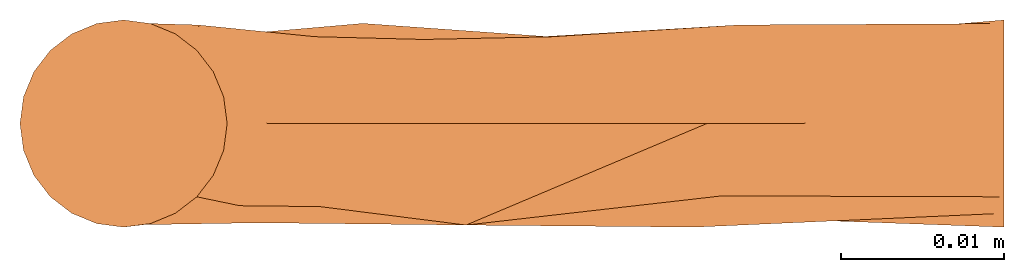
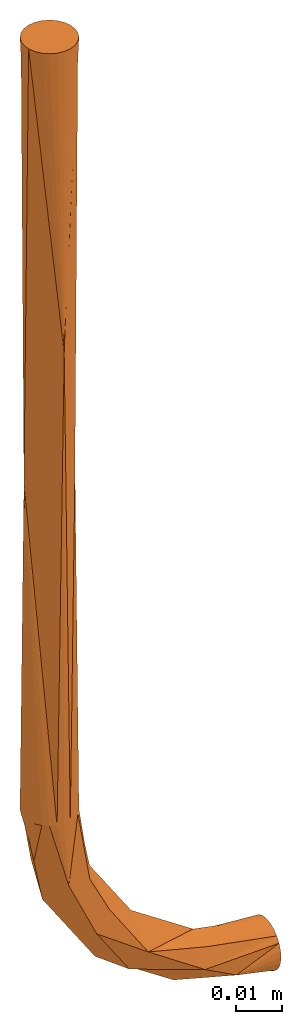
# One storey: 1 proxy.
"""IFC2X3 building model written with IfcOpenShell, lengths in feet."""

from ifc_helpers import new_model, entity, si_unit, converted_unit, derived_unit, direction, origin, place, context, subcontext, project, spatial, faceted_brep, source, transform, mapped, material, type_object, type_shapes, element, save


model = new_model("IFC2X3")

# Units and contexts
model_context = context("Model", 3, precision=0.0001, world=origin(), true_north=direction((6.12303176911189e-17, 1.0)))
body_context = subcontext(model_context, "Body", "Model", "MODEL_VIEW")
ifc_project = project(units=[converted_unit("LENGTHUNIT", "FOOT", entity("IfcRatioMeasure", 0.3048), si_unit("LENGTHUNIT", "METRE"), dimensions=[1, 0, 0, 0, 0, 0, 0]), converted_unit("AREAUNIT", "SQUARE FOOT", entity("IfcRatioMeasure", 0.09290304), si_unit("AREAUNIT", "SQUARE_METRE"), dimensions=[2, 0, 0, 0, 0, 0, 0]), converted_unit("VOLUMEUNIT", "CUBIC FOOT", entity("IfcRatioMeasure", 0.028316846592), si_unit("VOLUMEUNIT", "CUBIC_METRE"), dimensions=[3, 0, 0, 0, 0, 0, 0]), converted_unit("PLANEANGLEUNIT", "DEGREE", entity("IfcRatioMeasure", 0.0174532925199433), si_unit("PLANEANGLEUNIT", "RADIAN"), dimensions=[0, 0, 0, 0, 0, 0, 0]), si_unit("MASSUNIT", "GRAM", prefix="KILO"), derived_unit("MASSDENSITYUNIT", [(si_unit("MASSUNIT", "GRAM", prefix="KILO"), 1), (si_unit("LENGTHUNIT", "METRE"), -3)]), derived_unit("MOMENTOFINERTIAUNIT", [(si_unit("LENGTHUNIT", "METRE"), 4)]), si_unit("TIMEUNIT", "SECOND"), si_unit("FREQUENCYUNIT", "HERTZ"), si_unit("THERMODYNAMICTEMPERATUREUNIT", "DEGREE_CELSIUS"), derived_unit("THERMALTRANSMITTANCEUNIT", [(si_unit("MASSUNIT", "GRAM", prefix="KILO"), 1), (si_unit("THERMODYNAMICTEMPERATUREUNIT", "KELVIN"), -1), (si_unit("TIMEUNIT", "SECOND"), -3)]), derived_unit("VOLUMETRICFLOWRATEUNIT", [(si_unit("LENGTHUNIT", "METRE"), 3), (si_unit("TIMEUNIT", "SECOND"), -1)]), si_unit("ELECTRICCURRENTUNIT", "AMPERE"), si_unit("ELECTRICVOLTAGEUNIT", "VOLT"), si_unit("POWERUNIT", "WATT"), si_unit("FORCEUNIT", "NEWTON"), si_unit("ILLUMINANCEUNIT", "LUX"), si_unit("LUMINOUSFLUXUNIT", "LUMEN"), si_unit("LUMINOUSINTENSITYUNIT", "CANDELA"), derived_unit("USERDEFINED", [(si_unit("MASSUNIT", "GRAM", prefix="KILO"), -1), (si_unit("LENGTHUNIT", "METRE"), -2), (si_unit("TIMEUNIT", "SECOND"), 3), (si_unit("LUMINOUSFLUXUNIT", "LUMEN"), 1)]), derived_unit("LINEARVELOCITYUNIT", [(si_unit("LENGTHUNIT", "METRE"), 1), (si_unit("TIMEUNIT", "SECOND"), -1)]), si_unit("PRESSUREUNIT", "PASCAL"), derived_unit("USERDEFINED", [(si_unit("LENGTHUNIT", "METRE"), -2), (si_unit("MASSUNIT", "GRAM", prefix="KILO"), 1), (si_unit("TIMEUNIT", "SECOND"), -2)]), derived_unit("LINEARFORCEUNIT", [(si_unit("MASSUNIT", "GRAM", prefix="KILO"), 1), (si_unit("LENGTHUNIT", "METRE"), 1), (si_unit("TIMEUNIT", "SECOND"), -2), (si_unit("LENGTHUNIT", "METRE"), -1)]), derived_unit("PLANARFORCEUNIT", [(si_unit("MASSUNIT", "GRAM", prefix="KILO"), 1), (si_unit("LENGTHUNIT", "METRE"), 1), (si_unit("TIMEUNIT", "SECOND"), -2), (si_unit("LENGTHUNIT", "METRE"), -2)])], contexts=[model_context])

# Site, building, storey
site_placement = place(None, origin())
site = spatial("IfcSite", under=ifc_project, at=site_placement, CompositionType="ELEMENT")
building_placement = place(site_placement, origin())
building = spatial("IfcBuilding", under=site, at=building_placement, CompositionType="ELEMENT")
storey_placement = place(building_placement, origin())
storey = spatial("IfcBuildingStorey", under=building, at=storey_placement, Name="Level 1", CompositionType="ELEMENT", Elevation=0.0)

# Proxy
ifc_material = material()
building_element_proxy_type = type_object("IfcBuildingElementProxyType", Name="Generic Models 1:Generic Models 1", PredefinedType="NOTDEFINED", material=ifc_material)
shared_shape = source(origin(), body_context, "Body", "Brep", [
    faceted_brep([(0.00539206343963987, 0.020123454714352, 0.0), (0.0, 0.0208333333333298, 0.0), (-0.00539206343963183, 0.0201234547143521, 0.0), (-0.0104166666666627, 0.0180421959121723, 0.0), (-0.0147313912747158, 0.0147313912747163, 0.0), (-0.0180421959121719, 0.0104166666666633, 0.0), (-0.0201234547143517, 0.00539206343963248, 0.0), (-0.0208333333333295, 0.0, 0.0), (-0.0201234547143518, -0.00539206343963921, 0.0), (-0.0180421959121721, -0.01041666666667, 0.0), (-0.014731391274716, -0.0147313912747231, 0.0), (-0.010416666666663, -0.0180421959121793, 0.0), (-0.0053920634396322, -0.0201234547143591, 0.0), (0.0, -0.0208333333333369, 0.0), (0.00539206343963949, -0.0201234547143592, 0.0), (0.0104166666666703, -0.0180421959121795, 0.0), (0.0147313912747234, -0.0147313912747235, 0.0), (0.0180421959121795, -0.0104166666666704, 0.0), (0.0201234547143594, -0.00539206343963965, 0.0), (0.0208333333333372, 0.0, 0.0), (0.0201234547143595, 0.00539206343963216, 0.0), (0.0180421959121797, 0.010416666666663, 0.0), (0.0147313912747237, 0.0147313912747161, 0.0), (0.0104166666666707, 0.0180421959121722, 0.0), (-0.0147313912747163, -0.0147313912747231, -0.666666666666667), (-0.0208333333333296, 0.0, -0.377991522811074), (-0.0180421959121723, -0.01041666666667, -0.666666666666667), (-0.020123454714352, -0.00539206343963921, -0.666666666666667), (-0.0208333333333297, 0.0, -0.666666666666667), (0.0, -0.0208333333333369, -0.260715759323299), (0.0208333333333371, 0.0, -0.377991522479254), (0.0104166666666701, -0.0180421959121795, -0.666666666666667), (0.00539206343963925, -0.0201234547143592, -0.666666666666667), (-0.00539206343963245, -0.0201234547143591, -0.666666666666667), (0.0, -0.0208333333333369, -0.666666666666667), (-0.0104166666666632, -0.0180421959121793, -0.666666666666667), (0.0201234547143591, -0.00539206343963965, -0.666666666666667), (0.020833333333337, 0.0, -0.666666666666667), (0.0147313912747232, -0.0147313912747235, -0.666666666666667), (0.0180421959121793, -0.0104166666666704, -0.666666666666667), (0.0147313912747235, 0.0147313912747161, -0.666666666666667), (0.0180421959121795, 0.010416666666663, -0.666666666666667), (0.0201234547143592, 0.00539206343963216, -0.666666666666667), (-0.0104166666666629, 0.0180421959121723, -0.666666666666667), (-0.00539206343963209, 0.0201234547143521, -0.666666666666667), (0.0, 0.0208333333333298, -0.260715758334948), (0.0053920634396396, 0.020123454714352, -0.666666666666667), (0.0, 0.0208333333333298, -0.666666666666667), (0.0104166666666704, 0.0180421959121722, -0.666666666666667), (-0.0201234547143519, 0.00539206343963248, -0.666666666666667), (-0.014731391274716, 0.0147313912747163, -0.666666666666667), (-0.0180421959121721, 0.0104166666666633, -0.666666666666667), (0.177083333333337, 0.0201234547143515, -0.849142063439636), (0.177083333333337, 0.0208333333333292, -0.84375), (0.177083333333337, 0.0201234547143515, -0.838357936560364), (0.177083333333337, 0.0180421959121717, -0.833333333333334), (0.177083333333337, 0.0147313912747157, -0.82901860872528), (0.177083333333337, 0.0104166666666626, -0.825707804087824), (0.177083333333337, 0.00539206343963179, -0.823626545285645), (0.177083333333337, 0.0, -0.822916666666667), (0.177083333333337, -0.00539206343964003, -0.823626545285645), (0.177083333333337, -0.0104166666666708, -0.825707804087824), (0.177083333333337, -0.0147313912747239, -0.82901860872528), (0.177083333333337, -0.01804219591218, -0.833333333333334), (0.177083333333337, -0.0201234547143597, -0.838357936560364), (0.177083333333337, -0.0208333333333375, -0.84375), (0.177083333333337, -0.0201234547143597, -0.849142063439636), (0.177083333333337, -0.0180421959121799, -0.854166666666667), (0.177083333333337, -0.0147313912747239, -0.85848139127472), (0.177083333333337, -0.0104166666666708, -0.861792195912176), (0.177083333333337, -0.00539206343963997, -0.863873454714356), (0.177083333333337, 0.0, -0.864583333333333), (0.177083333333337, 0.00539206343963173, -0.863873454714356), (0.177083333333337, 0.0104166666666625, -0.861792195912176), (0.177083333333337, 0.0147313912747156, -0.85848139127472), (0.177083333333337, 0.0180421959121717, -0.854166666666667), (-0.0167950171069764, 0.0, -0.686968653313105), (-0.00576782414285532, 0.0, -0.742406095988924), (0.00405231312832818, -0.0203416522262716, -0.721735439177068), (-0.0127567008806232, 0.0, -0.707270639959544), (0.0270826060398489, -0.019958003126031, -0.771596626561765), (0.015683646040322, 0.0, -0.774510489882714), (0.0371351162234992, 0.0, -0.806614883776504), (0.0233785758235232, -0.0165205759206884, -0.724969404498046), (0.101343904011079, 0.0, -0.849517824142859), (0.141488527996444, -0.019548815114255, -0.847481946984691), (0.114935361951923, -0.0208329130348945, -0.832627572794037), (0.0688880787012024, -0.0204132882658536, -0.801557146756203), (0.0394860560147177, -0.0166971786815335, -0.757044153324669), (0.117289047026291, 0.0, -0.811022843621555), (0.0665978987729388, 0.0, -0.777152101227065), (0.0327271563784484, 0.0, -0.726460952973712), (0.136479359664191, 0.0, -0.814840034139116), (0.056542466725499, -0.0151923541103726, -0.815261620656422), (0.0289099658411618, 0.0, -0.707270640236642), (0.0692395101172893, 0.0, -0.828066353959682), (0.0496625275756936, 0.0, -0.751806527100388), (0.120299596848145, -0.0145446419317564, -0.818567671524957), (0.156781346667261, 0.0, -0.860545017103074), (0.136479360001186, 0.0, -0.856506700872815), (0.123773793977906, 0.019845243816533, -0.828874619445264), (-0.00573043831103176, 0.0165989003606419, -0.717214078015133), (0.0148753807133672, 0.0198452437972468, -0.719976206311402), (0.126535922062734, 0.0165989003245105, -0.849480438381988), (0.0804714499011899, 0.0172660350221339, -0.828806979368249), (0.0149430206039226, 0.0172660351047418, -0.763278549813091), (0.0859066587732985, 0.0174556896109953, -0.805039342583835), (0.0603176933633829, 0.016920193061464, -0.783145269972555), (0.0384645942426614, 0.0174772750202281, -0.757529383861972), (0.0481286232954352, 0.0201515316591063, -0.795621375760561)], [[[0, 1, 2, 3, 4, 5, 6, 7, 8, 9, 10, 11, 12, 13, 14, 15, 16, 17, 18, 19, 20, 21, 22, 23]], [[24, 25, 26]], [[27, 25, 28]], [[8, 7, 25]], [[29, 30, 18]], [[31, 30, 32]], [[33, 34, 29]], [[25, 35, 33]], [[17, 29, 18]], [[36, 37, 30]], [[19, 18, 30]], [[29, 11, 10]], [[9, 8, 29]], [[24, 35, 25]], [[8, 25, 29]], [[9, 29, 10]], [[38, 30, 31]], [[29, 25, 33]], [[30, 29, 32]], [[30, 39, 36]], [[25, 27, 26]], [[15, 14, 29]], [[29, 34, 32]], [[12, 11, 29]], [[30, 38, 39]], [[13, 12, 29]], [[14, 13, 29]], [[16, 15, 29]], [[29, 17, 16]], [[40, 30, 41]], [[42, 30, 37]], [[20, 19, 30]], [[30, 42, 41]], [[43, 25, 44]], [[45, 46, 47]], [[30, 48, 46]], [[5, 45, 6]], [[40, 48, 30]], [[45, 23, 22]], [[30, 45, 20]], [[45, 21, 20]], [[45, 22, 21]], [[49, 28, 25]], [[7, 6, 25]], [[50, 25, 43]], [[45, 30, 46]], [[25, 45, 44]], [[25, 51, 49]], [[45, 25, 6]], [[3, 2, 45]], [[44, 45, 47]], [[0, 23, 45]], [[50, 51, 25]], [[45, 1, 0]], [[1, 45, 2]], [[4, 3, 45]], [[45, 5, 4]], [[52, 53, 54, 55, 56, 57, 58, 59, 60, 61, 62, 63, 64, 65, 66, 67, 68, 69, 70, 71, 72, 73, 74, 75]], [[27, 28, 76]], [[77, 78, 79]], [[79, 24, 76]], [[76, 24, 26]], [[26, 27, 76]], [[80, 77, 81, 82]], [[78, 35, 79]], [[35, 24, 79]], [[83, 38, 78]], [[78, 33, 35]], [[34, 33, 78]], [[84, 85, 86]], [[87, 88, 80]], [[86, 63, 62]], [[87, 89, 90]], [[78, 32, 34]], [[83, 88, 91]], [[38, 31, 78]], [[60, 59, 92]], [[93, 80, 82]], [[39, 94, 36]], [[78, 31, 32]], [[80, 93, 87]], [[38, 83, 39]], [[86, 87, 93]], [[84, 86, 95]], [[83, 91, 94]], [[96, 91, 88, 90]], [[80, 83, 78]], [[93, 82, 95]], [[87, 97, 89]], [[85, 66, 65]], [[66, 85, 67]], [[65, 64, 85]], [[98, 69, 68]], [[71, 70, 98]], [[69, 98, 70]], [[85, 68, 67]], [[36, 94, 37]], [[99, 98, 68]], [[39, 83, 94]], [[83, 80, 88]], [[92, 89, 97]], [[60, 97, 61]], [[86, 93, 95]], [[92, 97, 60]], [[85, 99, 68]], [[85, 63, 86]], [[87, 90, 88]], [[62, 61, 97]], [[97, 86, 62]], [[84, 99, 85]], [[63, 85, 64]], [[77, 80, 78]], [[97, 87, 86]], [[92, 57, 100]], [[79, 101, 77]], [[46, 102, 101]], [[100, 103, 104]], [[48, 102, 46]], [[102, 40, 41]], [[102, 41, 94]], [[82, 104, 84, 95]], [[102, 94, 91]], [[76, 51, 50]], [[94, 41, 42]], [[51, 76, 49]], [[105, 101, 102]], [[102, 48, 40]], [[50, 79, 76]], [[89, 106, 90]], [[76, 28, 49]], [[90, 106, 107]], [[101, 50, 43]], [[100, 106, 89]], [[44, 47, 101]], [[100, 54, 103]], [[46, 101, 47]], [[77, 101, 105]], [[43, 44, 101]], [[105, 82, 81, 77]], [[108, 90, 107]], [[108, 109, 105]], [[92, 58, 57]], [[109, 108, 107]], [[56, 100, 57]], [[104, 109, 106]], [[99, 74, 98]], [[108, 91, 96, 90]], [[79, 50, 101]], [[72, 71, 98]], [[58, 92, 59]], [[108, 105, 102]], [[54, 100, 55]], [[55, 100, 56]], [[42, 37, 94]], [[54, 53, 103]], [[52, 75, 103]], [[89, 92, 100]], [[74, 99, 103]], [[75, 74, 103]], [[102, 91, 108]], [[53, 52, 103]], [[73, 72, 98]], [[82, 105, 109]], [[103, 99, 84]], [[82, 109, 104]], [[74, 73, 98]], [[104, 103, 84]], [[109, 107, 106]], [[106, 100, 104]]]),
])
type_shapes(building_element_proxy_type, [shared_shape])
proxy_placement = place(storey_placement, origin())
element("IfcBuildingElementProxy", 1, at=proxy_placement, inside=storey, type_object=building_element_proxy_type, material=ifc_material, Name="Generic Models 1:Generic Models 1", ObjectType="Generic Models 1:Generic Models 1", context=body_context, shape_type="MappedRepresentation", body=[
    mapped(shared_shape, transform((0.0, 0.0, 0.0), scale=1.0)),
])

save(model, "model.ifc")
